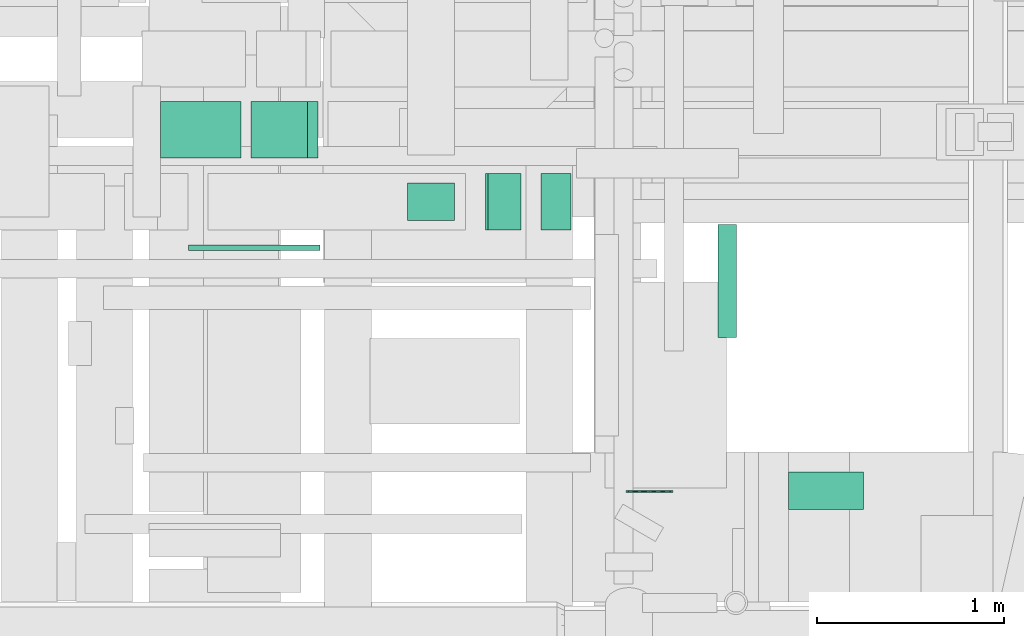
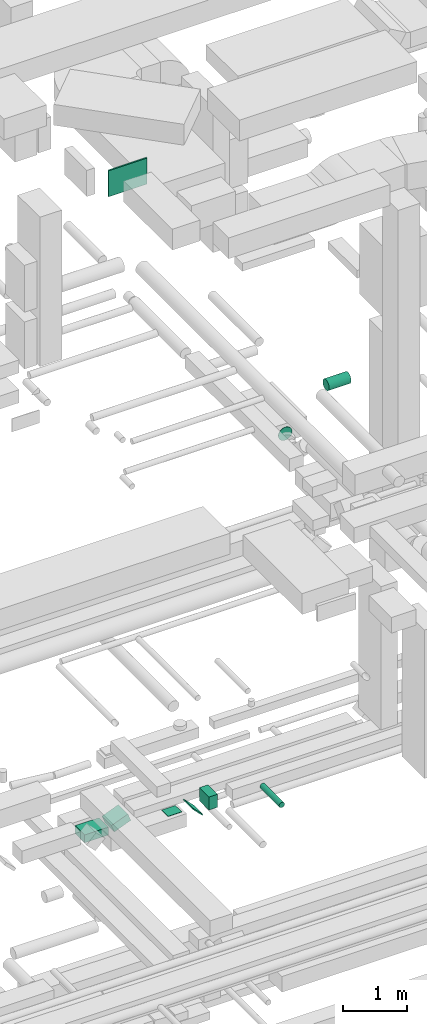
# One storey, part 173 of 337: 9 flow segments.
"""IFC2X3 building model written with IfcOpenShell, lengths in millimetres."""

from ifc_helpers import new_model, entity, si_unit, converted_unit, derived_unit, direction, frame, frame_2d, origin, origin_2d_with_axis, place, context, subcontext, project, spatial, rectangle, circle, extrude, type_object, element, save


model = new_model("IFC2X3")

# Units and contexts
model_context = context("Model", 3, precision=0.01, world=origin(), true_north=direction((6.12303176911189e-17, 1.0)))
body_context = subcontext(model_context, "Body", "Model", "MODEL_VIEW")
ifc_project = project(units=[si_unit("LENGTHUNIT", "METRE", prefix="MILLI"), si_unit("AREAUNIT", "SQUARE_METRE"), si_unit("VOLUMEUNIT", "CUBIC_METRE"), converted_unit("PLANEANGLEUNIT", "DEGREE", entity("IfcRatioMeasure", 0.0174532925199433), si_unit("PLANEANGLEUNIT", "RADIAN"), dimensions=[0, 0, 0, 0, 0, 0, 0]), si_unit("MASSUNIT", "GRAM", prefix="KILO"), derived_unit("MASSDENSITYUNIT", [(si_unit("MASSUNIT", "GRAM", prefix="KILO"), 1), (si_unit("LENGTHUNIT", "METRE"), -3)]), derived_unit("MOMENTOFINERTIAUNIT", [(si_unit("LENGTHUNIT", "METRE"), 4)]), si_unit("TIMEUNIT", "SECOND"), si_unit("FREQUENCYUNIT", "HERTZ"), si_unit("THERMODYNAMICTEMPERATUREUNIT", "DEGREE_CELSIUS"), derived_unit("THERMALTRANSMITTANCEUNIT", [(si_unit("MASSUNIT", "GRAM", prefix="KILO"), 1), (si_unit("THERMODYNAMICTEMPERATUREUNIT", "KELVIN"), -1), (si_unit("TIMEUNIT", "SECOND"), -3)]), derived_unit("VOLUMETRICFLOWRATEUNIT", [(si_unit("LENGTHUNIT", "METRE"), 3), (si_unit("TIMEUNIT", "SECOND"), -1)]), derived_unit("MASSFLOWRATEUNIT", [(si_unit("MASSUNIT", "GRAM", prefix="KILO"), 1), (si_unit("TIMEUNIT", "SECOND"), -1)]), derived_unit("ROTATIONALFREQUENCYUNIT", [(si_unit("TIMEUNIT", "SECOND"), -1)]), si_unit("ELECTRICCURRENTUNIT", "AMPERE"), si_unit("ELECTRICVOLTAGEUNIT", "VOLT"), si_unit("POWERUNIT", "WATT"), si_unit("FORCEUNIT", "NEWTON", prefix="KILO"), si_unit("ILLUMINANCEUNIT", "LUX"), si_unit("LUMINOUSFLUXUNIT", "LUMEN"), si_unit("LUMINOUSINTENSITYUNIT", "CANDELA"), derived_unit("USERDEFINED", [(si_unit("MASSUNIT", "GRAM", prefix="KILO"), -1), (si_unit("LENGTHUNIT", "METRE"), -2), (si_unit("TIMEUNIT", "SECOND"), 3), (si_unit("LUMINOUSFLUXUNIT", "LUMEN"), 1)]), derived_unit("LINEARVELOCITYUNIT", [(si_unit("LENGTHUNIT", "METRE"), 1), (si_unit("TIMEUNIT", "SECOND"), -1)]), si_unit("PRESSUREUNIT", "PASCAL"), derived_unit("USERDEFINED", [(si_unit("LENGTHUNIT", "METRE"), -2), (si_unit("MASSUNIT", "GRAM", prefix="KILO"), 1), (si_unit("TIMEUNIT", "SECOND"), -2)]), derived_unit("LINEARFORCEUNIT", [(si_unit("MASSUNIT", "GRAM", prefix="KILO"), 1), (si_unit("LENGTHUNIT", "METRE"), 1), (si_unit("TIMEUNIT", "SECOND"), -2), (si_unit("LENGTHUNIT", "METRE"), -1)]), derived_unit("PLANARFORCEUNIT", [(si_unit("MASSUNIT", "GRAM", prefix="KILO"), 1), (si_unit("LENGTHUNIT", "METRE"), 1), (si_unit("TIMEUNIT", "SECOND"), -2), (si_unit("LENGTHUNIT", "METRE"), -2)])], contexts=[model_context])

# Site, building, storey
site_placement = place(None, origin())
site = spatial("IfcSite", under=ifc_project, at=site_placement, CompositionType="ELEMENT")
building_placement = place(site_placement, origin())
building = spatial("IfcBuilding", under=site, at=building_placement, CompositionType="ELEMENT")
storey_placement = place(building_placement, origin())
storey = spatial("IfcBuildingStorey", under=building, at=storey_placement, CompositionType="ELEMENT", Elevation=0.0)

# Flow segments
duct_segment_type_1 = type_object("IfcDuctSegmentType", PredefinedType="NOTDEFINED")
flow_segment_1_placement = place(storey_placement, frame((38020.04, 14410.54, 18750.0)))
element("IfcFlowSegment", 1, at=flow_segment_1_placement, inside=storey, type_object=duct_segment_type_1, context=body_context, shape_type="SweptSolid", body=[
    extrude(rectangle(XDim=428.633569928, YDim=300.000000000001, at=origin_2d_with_axis()), frame((214.32, 150.0, 0.0)), (0.0, 0.0, 1.0), 150.000000000001),
])
flow_segment_2_placement = place(storey_placement, frame((39754.14, 14025.53, 18842.16)))
element("IfcFlowSegment", 2, at=flow_segment_2_placement, inside=storey, type_object=duct_segment_type_1, context=body_context, shape_type="SweptSolid", body=[
    extrude(rectangle(XDim=19.6699141101101, YDim=250.000000000004, at=origin_2d_with_axis()), frame((95.34, 0.0, 95.34), z_axis=(0.0, 1.0, 0.0), x_axis=(0.707106781186437, 0.0, 0.707106781186658)), (0.0, 0.0, 1.0), 300.000000000001),
])
flow_segment_3_placement = place(storey_placement, frame((40050.89, 14025.53, 18900.0)))
element("IfcFlowSegment", 3, at=flow_segment_3_placement, inside=storey, type_object=duct_segment_type_1, context=body_context, shape_type="SweptSolid", body=[
    extrude(rectangle(XDim=161.091270347425, YDim=299.999999999999, at=origin_2d_with_axis()), frame((80.55, 150.0, 0.0)), (0.0, 0.0, 1.0), 249.999999999999),
])
flow_segment_4_placement = place(storey_placement, frame((39339.82, 14074.64, 18995.0)))
element("IfcFlowSegment", 4, at=flow_segment_4_placement, inside=storey, type_object=duct_segment_type_1, context=body_context, shape_type="SweptSolid", body=[
    extrude(rectangle(XDim=200.000000000002, YDim=250.000000000004, at=origin_2d_with_axis()), frame((125.0, 100.0, 0.0), z_axis=(0.0, 0.0, 1.0), x_axis=(0.0, -1.0, 0.0)), (0.0, 0.0, 1.0), 5.00000000002918),
])
flow_segment_5_placement = place(storey_placement, frame((38503.7, 14410.54, 18770.92)))
element("IfcFlowSegment", 5, at=flow_segment_5_placement, inside=storey, type_object=duct_segment_type_1, context=body_context, shape_type="SweptSolid", body=[
    extrude(rectangle(XDim=150.000000000002, YDim=300.000000000001, at=frame_2d((0.0, 0.0), x_axis=(0.0, 1.0))), frame((27.51, 150.0, 69.77), z_axis=(0.930282021712724, 0.0, 0.366845144547514), x_axis=(0.0, 1.0, 0.0)), (0.0, 0.0, 1.0), 323.370532591051),
])
flow_segment_6_placement = place(storey_placement, frame((38170.03, 13916.3, 31400.0)))
element("IfcFlowSegment", 6, at=flow_segment_6_placement, inside=storey, type_object=duct_segment_type_1, context=body_context, shape_type="SweptSolid", body=[
    extrude(rectangle(XDim=28.301898150094, YDim=700.000000000001, at=origin_2d_with_axis()), frame((350.0, 14.15, 0.0), z_axis=(0.0, 0.0, 1.0), x_axis=(0.0, 1.0, 0.0)), (0.0, 0.0, 1.0), 499.999999999999),
])
duct_segment_type_2 = type_object("IfcDuctSegmentType", PredefinedType="NOTDEFINED")
flow_segment_7_placement = place(storey_placement, frame((40994.71, 13450.84, 18948.4)))
element("IfcFlowSegment", 7, at=flow_segment_7_placement, inside=storey, type_object=duct_segment_type_2, context=body_context, shape_type="SweptSolid", body=[
    extrude(circle(Radius=50.0, at=origin_2d_with_axis()), frame((51.6, 0.0, 51.6), z_axis=(0.0, 1.0, 0.0), x_axis=(-1.0, 0.0, 0.0)), (0.0, 0.0, 1.0), 604.687162665472),
])
flow_segment_8_placement = place(storey_placement, frame((41373.1, 12529.91, 27348.4)))
element("IfcFlowSegment", 8, at=flow_segment_8_placement, inside=storey, type_object=duct_segment_type_2, context=body_context, shape_type="SweptSolid", body=[
    extrude(circle(Radius=100.0, at=origin_2d_with_axis()), frame((0.0, 101.6, 101.6), z_axis=(1.0, 0.0, 0.0), x_axis=(0.0, -1.0, 0.0)), (0.0, 0.0, 1.0), 400.000000000022),
])
flow_segment_9_placement = place(storey_placement, frame((40504.03, 12623.85, 26648.4)))
element("IfcFlowSegment", 9, at=flow_segment_9_placement, inside=storey, type_object=duct_segment_type_2, context=body_context, shape_type="SweptSolid", body=[
    extrude(circle(Radius=125.0, at=origin_2d_with_axis()), frame((126.6, 0.0, 126.6), z_axis=(0.0, 1.0, 0.0), x_axis=(1.0, 0.0, 0.0)), (0.0, 0.0, 1.0), 7.65967350982998),
])

save(model, "model.ifc")
